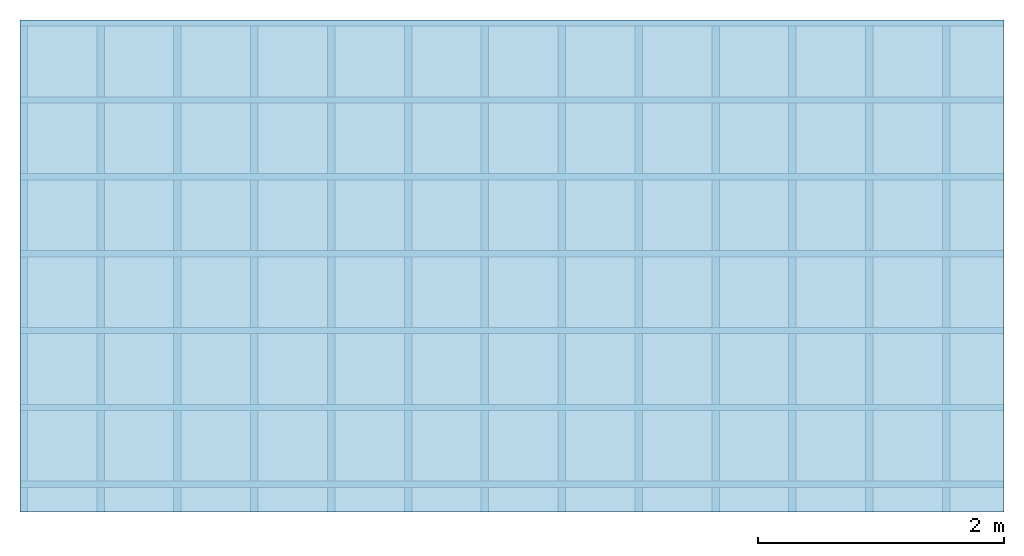
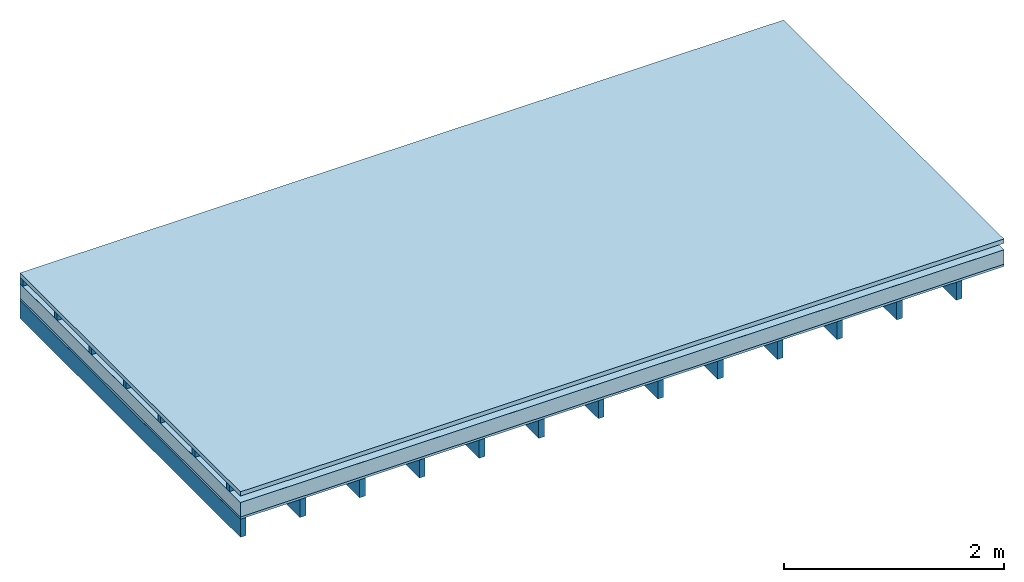
# One storey: 4 plates, 2 members, 1 element without a shape of its own.
"""IFC4 building model written with IfcOpenShell, lengths in metres."""

from ifc_helpers import new_model, si_unit, derived_unit, direction, frame, frame_2d, origin, origin_with_axes, place, context, project, spatial, rectangle, extrude, material, layer, layer_set, type_object, element, aggregate, save


model = new_model("IFC4")

# Units and contexts
plan_context = context("Plan", 3, precision=1e-05, world=origin(), true_north=direction((0.0, 1.0)))
model_context = context("Model", 3, precision=1e-05, world=origin(), true_north=direction((0.0, 1.0)))
ifc_project = project(units=[si_unit("LENGTHUNIT", "METRE"), derived_unit("SOUNDPRESSUREUNIT", [(si_unit("PRESSUREUNIT", "PASCAL", prefix="MICRO"), 0)]), si_unit("ENERGYUNIT", "JOULE", prefix="MEGA"), si_unit("MASSUNIT", "GRAM", prefix="KILO"), derived_unit("THERMALTRANSMITTANCEUNIT", [(si_unit("POWERUNIT", "WATT"), 1), (si_unit("AREAUNIT", "SQUARE_METRE"), -1), (si_unit("THERMODYNAMICTEMPERATUREUNIT", "KELVIN"), -1)]), derived_unit("AREADENSITYUNIT", [(si_unit("MASSUNIT", "GRAM", prefix="KILO"), 1), (si_unit("AREAUNIT", "SQUARE_METRE"), -1)]), derived_unit("USERDEFINED", [(si_unit("ENERGYUNIT", "JOULE", prefix="MEGA"), 1), (si_unit("AREAUNIT", "SQUARE_METRE"), -1)])], contexts=[plan_context, model_context])

# Site, building, storey
site = spatial("IfcSite", under=ifc_project)
building_placement = place(None, origin())
building = spatial("IfcBuilding", under=site, at=building_placement)
storey_placement = place(building_placement, origin())
storey = spatial("IfcBuildingStorey", under=building, at=storey_placement)

# Slab, members, plates
ifc_material_1 = material(Name="Roof tiles", Category="03.015")
ifc_layer_1 = layer(ifc_material_1, 0.047, Name="Roofing")
ifc_layer_2 = layer(None, 0.072, Name="Battens / profiles")
ifc_material_2 = material(Name="Roofing underlay", Category="09.008")
ifc_layer_3 = layer(ifc_material_2, 0.00018, Name="Under the roof")
ifc_material_3 = material(Category="10.008")
ifc_layer_4 = layer(ifc_material_3, 0.16, Name="Exterior insulation layer 1")
ifc_material_4 = material(Category="07.001")
ifc_layer_5 = layer(ifc_material_4, 0.025, Name="Sub-floor")
ifc_material_5 = material(Name="of the art")
ifc_layer_6 = layer(ifc_material_5, 0.0, Name="Bond")
ifc_layer_7 = layer(None, 0.2, Name="Supporting structure")
ifc_layer_set = layer_set([ifc_layer_1, ifc_layer_2, ifc_layer_3, ifc_layer_4, ifc_layer_5, ifc_layer_6, ifc_layer_7])
slab_type = type_object("IfcSlabType", Name="E0055", PredefinedType="NOTDEFINED", material=ifc_layer_set)
slab_placement = place(None, frame((0.0, 0.0, 0.0), z_axis=(0.0, 0.0, -1.0), x_axis=(1.0, 0.0, 0.0)))
slab = element("IfcSlab", 1, at=slab_placement, inside=storey, type_object=slab_type, material=ifc_layer_set, Name="Slab #1")
ifc_material_6 = material()
member_1_placement = place(slab_placement, origin())
member_1 = element("IfcMember", 2, at=member_1_placement, material=ifc_material_6, Name="Battens / profiles", context=plan_context, shape_type="SweptSolid", body=[
    extrude(rectangle(XDim=0.05, YDim=0.072, at=frame_2d((0.025, 0.036), x_axis=(1.0, 0.0))), frame((0.0, 0.0, 0.047), z_axis=(1.0, 0.0, 0.0), x_axis=(0.0, 1.0, 0.0)), (0.0, 0.0, 1.0), 8.0),
    extrude(rectangle(XDim=0.05, YDim=0.072, at=frame_2d((0.025, 0.036), x_axis=(1.0, 0.0))), frame((0.0, 0.625, 0.047), z_axis=(1.0, 0.0, 0.0), x_axis=(0.0, 1.0, 0.0)), (0.0, 0.0, 1.0), 8.0),
    extrude(rectangle(XDim=0.05, YDim=0.072, at=frame_2d((0.025, 0.036), x_axis=(1.0, 0.0))), frame((0.0, 1.25, 0.047), z_axis=(1.0, 0.0, 0.0), x_axis=(0.0, 1.0, 0.0)), (0.0, 0.0, 1.0), 8.0),
    extrude(rectangle(XDim=0.05, YDim=0.072, at=frame_2d((0.025, 0.036), x_axis=(1.0, 0.0))), frame((0.0, 1.875, 0.047), z_axis=(1.0, 0.0, 0.0), x_axis=(0.0, 1.0, 0.0)), (0.0, 0.0, 1.0), 8.0),
    extrude(rectangle(XDim=0.05, YDim=0.072, at=frame_2d((0.025, 0.036), x_axis=(1.0, 0.0))), frame((0.0, 2.5, 0.047), z_axis=(1.0, 0.0, 0.0), x_axis=(0.0, 1.0, 0.0)), (0.0, 0.0, 1.0), 8.0),
    extrude(rectangle(XDim=0.05, YDim=0.072, at=frame_2d((0.025, 0.036), x_axis=(1.0, 0.0))), frame((0.0, 3.125, 0.047), z_axis=(1.0, 0.0, 0.0), x_axis=(0.0, 1.0, 0.0)), (0.0, 0.0, 1.0), 8.0),
    extrude(rectangle(XDim=0.05, YDim=0.072, at=frame_2d((0.025, 0.036), x_axis=(1.0, 0.0))), frame((0.0, 3.75, 0.047), z_axis=(1.0, 0.0, 0.0), x_axis=(0.0, 1.0, 0.0)), (0.0, 0.0, 1.0), 8.0),
])
ifc_material_7 = material()
member_2_placement = place(slab_placement, origin())
member_2 = element("IfcMember", 3, at=member_2_placement, material=ifc_material_7, Name="Supporting structure", context=plan_context, shape_type="SweptSolid", body=[
    extrude(rectangle(XDim=0.06, YDim=0.2, at=frame_2d((0.03, 0.1), x_axis=(1.0, 0.0))), frame((0.0, 4.0, 0.30418), z_axis=(0.0, -1.0, 0.0), x_axis=(1.0, 0.0, 0.0)), (0.0, 0.0, 1.0), 4.0),
    extrude(rectangle(XDim=0.06, YDim=0.2, at=frame_2d((0.03, 0.1), x_axis=(1.0, 0.0))), frame((0.625, 4.0, 0.30418), z_axis=(0.0, -1.0, 0.0), x_axis=(1.0, 0.0, 0.0)), (0.0, 0.0, 1.0), 4.0),
    extrude(rectangle(XDim=0.06, YDim=0.2, at=frame_2d((0.03, 0.1), x_axis=(1.0, 0.0))), frame((1.25, 4.0, 0.30418), z_axis=(0.0, -1.0, 0.0), x_axis=(1.0, 0.0, 0.0)), (0.0, 0.0, 1.0), 4.0),
    extrude(rectangle(XDim=0.06, YDim=0.2, at=frame_2d((0.03, 0.1), x_axis=(1.0, 0.0))), frame((1.875, 4.0, 0.30418), z_axis=(0.0, -1.0, 0.0), x_axis=(1.0, 0.0, 0.0)), (0.0, 0.0, 1.0), 4.0),
    extrude(rectangle(XDim=0.06, YDim=0.2, at=frame_2d((0.03, 0.1), x_axis=(1.0, 0.0))), frame((2.5, 4.0, 0.30418), z_axis=(0.0, -1.0, 0.0), x_axis=(1.0, 0.0, 0.0)), (0.0, 0.0, 1.0), 4.0),
    extrude(rectangle(XDim=0.06, YDim=0.2, at=frame_2d((0.03, 0.1), x_axis=(1.0, 0.0))), frame((3.125, 4.0, 0.30418), z_axis=(0.0, -1.0, 0.0), x_axis=(1.0, 0.0, 0.0)), (0.0, 0.0, 1.0), 4.0),
    extrude(rectangle(XDim=0.06, YDim=0.2, at=frame_2d((0.03, 0.1), x_axis=(1.0, 0.0))), frame((3.75, 4.0, 0.30418), z_axis=(0.0, -1.0, 0.0), x_axis=(1.0, 0.0, 0.0)), (0.0, 0.0, 1.0), 4.0),
    extrude(rectangle(XDim=0.06, YDim=0.2, at=frame_2d((0.03, 0.1), x_axis=(1.0, 0.0))), frame((4.375, 4.0, 0.30418), z_axis=(0.0, -1.0, 0.0), x_axis=(1.0, 0.0, 0.0)), (0.0, 0.0, 1.0), 4.0),
    extrude(rectangle(XDim=0.06, YDim=0.2, at=frame_2d((0.03, 0.1), x_axis=(1.0, 0.0))), frame((5.0, 4.0, 0.30418), z_axis=(0.0, -1.0, 0.0), x_axis=(1.0, 0.0, 0.0)), (0.0, 0.0, 1.0), 4.0),
    extrude(rectangle(XDim=0.06, YDim=0.2, at=frame_2d((0.03, 0.1), x_axis=(1.0, 0.0))), frame((5.625, 4.0, 0.30418), z_axis=(0.0, -1.0, 0.0), x_axis=(1.0, 0.0, 0.0)), (0.0, 0.0, 1.0), 4.0),
    extrude(rectangle(XDim=0.06, YDim=0.2, at=frame_2d((0.03, 0.1), x_axis=(1.0, 0.0))), frame((6.25, 4.0, 0.30418), z_axis=(0.0, -1.0, 0.0), x_axis=(1.0, 0.0, 0.0)), (0.0, 0.0, 1.0), 4.0),
    extrude(rectangle(XDim=0.06, YDim=0.2, at=frame_2d((0.03, 0.1), x_axis=(1.0, 0.0))), frame((6.875, 4.0, 0.30418), z_axis=(0.0, -1.0, 0.0), x_axis=(1.0, 0.0, 0.0)), (0.0, 0.0, 1.0), 4.0),
    extrude(rectangle(XDim=0.06, YDim=0.2, at=frame_2d((0.03, 0.1), x_axis=(1.0, 0.0))), frame((7.5, 4.0, 0.30418), z_axis=(0.0, -1.0, 0.0), x_axis=(1.0, 0.0, 0.0)), (0.0, 0.0, 1.0), 4.0),
])
plate_1_placement = place(slab_placement, origin())
plate_1 = element("IfcPlate", 4, at=plate_1_placement, material=ifc_material_1, Name="Roofing", context=plan_context, shape_type="SweptSolid", body=[
    extrude(rectangle(XDim=8.0, YDim=4.0, at=frame_2d((4.0, 2.0), x_axis=(1.0, 0.0))), origin_with_axes(), (0.0, 0.0, 1.0), 0.047),
])
plate_2_placement = place(slab_placement, origin())
plate_2 = element("IfcPlate", 5, at=plate_2_placement, material=ifc_material_2, Name="Under the roof", context=plan_context, shape_type="SweptSolid", body=[
    extrude(rectangle(XDim=8.0, YDim=4.0, at=frame_2d((4.0, 2.0), x_axis=(1.0, 0.0))), frame((0.0, 0.0, 0.119), z_axis=(0.0, 0.0, 1.0), x_axis=(1.0, 0.0, 0.0)), (0.0, 0.0, 1.0), 0.00018),
])
plate_3_placement = place(slab_placement, origin())
plate_3 = element("IfcPlate", 6, at=plate_3_placement, material=ifc_material_3, Name="Exterior insulation layer 1", context=plan_context, shape_type="SweptSolid", body=[
    extrude(rectangle(XDim=8.0, YDim=4.0, at=frame_2d((4.0, 2.0), x_axis=(1.0, 0.0))), frame((0.0, 0.0, 0.11918), z_axis=(0.0, 0.0, 1.0), x_axis=(1.0, 0.0, 0.0)), (0.0, 0.0, 1.0), 0.16),
])
plate_4_placement = place(slab_placement, origin())
plate_4 = element("IfcPlate", 7, at=plate_4_placement, material=ifc_material_4, Name="Sub-floor", context=plan_context, shape_type="SweptSolid", body=[
    extrude(rectangle(XDim=8.0, YDim=4.0, at=frame_2d((4.0, 2.0), x_axis=(1.0, 0.0))), frame((0.0, 0.0, 0.27918), z_axis=(0.0, 0.0, 1.0), x_axis=(1.0, 0.0, 0.0)), (0.0, 0.0, 1.0), 0.025),
])
aggregate(slab, [plate_1, member_1, plate_2, plate_3, plate_4, member_2])

save(model, "model.ifc")
